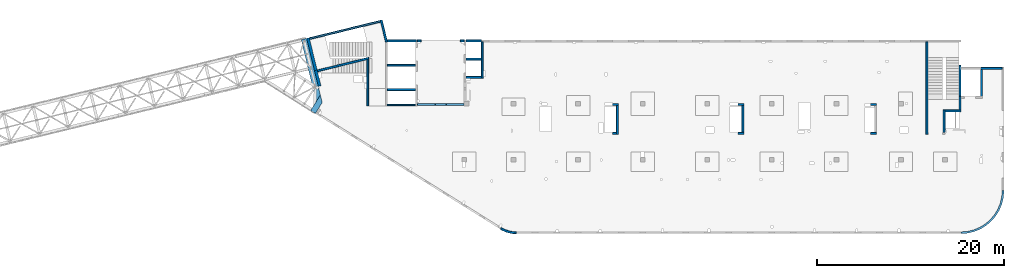
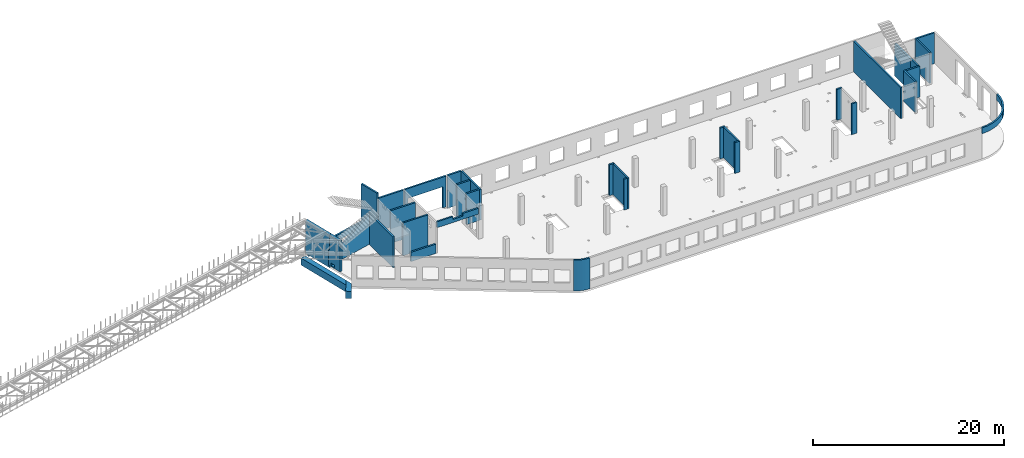
# One storey, part 15 of 66: 35 walls, 3 openings.
"""IFC4 building model written with IfcOpenShell, lengths in millimetres."""

from ifc_helpers import new_model, entity, si_unit, converted_unit, derived_unit, direction, frame, origin, place, context, subcontext, project, spatial, indexed_curve, outline, extrude, polygons, material, type_object, element, save


model = new_model("IFC4")

# Units and contexts
model_context = context("Model", 3, precision=0.01, world=origin(), true_north=direction((6.12303176911189e-17, 1.0)))
plan_context = context("Plan", 3, precision=0.01, world=origin(), true_north=direction((6.12303176911189e-17, 1.0)))
body_context = subcontext(model_context, "Body", "Model", "MODEL_VIEW")
ifc_project = project(units=[si_unit("LENGTHUNIT", "METRE", prefix="MILLI"), si_unit("AREAUNIT", "SQUARE_METRE"), si_unit("VOLUMEUNIT", "CUBIC_METRE"), converted_unit("PLANEANGLEUNIT", "DEGREE", entity("IfcRatioMeasure", 0.0174532925199433), si_unit("PLANEANGLEUNIT", "RADIAN"), dimensions=[0, 0, 0, 0, 0, 0, 0]), si_unit("MASSUNIT", "GRAM", prefix="KILO"), derived_unit("MASSDENSITYUNIT", [(si_unit("MASSUNIT", "GRAM", prefix="KILO"), 1), (si_unit("LENGTHUNIT", "METRE"), -3)]), derived_unit("MOMENTOFINERTIAUNIT", [(si_unit("LENGTHUNIT", "METRE"), 4)]), si_unit("TIMEUNIT", "SECOND"), si_unit("FREQUENCYUNIT", "HERTZ"), si_unit("THERMODYNAMICTEMPERATUREUNIT", "DEGREE_CELSIUS"), derived_unit("THERMALTRANSMITTANCEUNIT", [(si_unit("MASSUNIT", "GRAM", prefix="KILO"), 1), (si_unit("THERMODYNAMICTEMPERATUREUNIT", "KELVIN"), -1), (si_unit("TIMEUNIT", "SECOND"), -3)]), derived_unit("VOLUMETRICFLOWRATEUNIT", [(si_unit("LENGTHUNIT", "METRE"), 3), (si_unit("TIMEUNIT", "SECOND"), -1)]), derived_unit("MASSFLOWRATEUNIT", [(si_unit("MASSUNIT", "GRAM", prefix="KILO"), 1), (si_unit("TIMEUNIT", "SECOND"), -1)]), derived_unit("ROTATIONALFREQUENCYUNIT", [(si_unit("TIMEUNIT", "SECOND"), -1)]), si_unit("ELECTRICCURRENTUNIT", "AMPERE"), si_unit("ELECTRICVOLTAGEUNIT", "VOLT"), si_unit("POWERUNIT", "WATT"), si_unit("FORCEUNIT", "NEWTON", prefix="KILO"), si_unit("ILLUMINANCEUNIT", "LUX"), si_unit("LUMINOUSFLUXUNIT", "LUMEN"), si_unit("LUMINOUSINTENSITYUNIT", "CANDELA"), derived_unit("USERDEFINED", [(si_unit("MASSUNIT", "GRAM", prefix="KILO"), -1), (si_unit("LENGTHUNIT", "METRE"), -2), (si_unit("TIMEUNIT", "SECOND"), 3), (si_unit("LUMINOUSFLUXUNIT", "LUMEN"), 1)]), derived_unit("LINEARVELOCITYUNIT", [(si_unit("LENGTHUNIT", "METRE"), 1), (si_unit("TIMEUNIT", "SECOND"), -1)]), si_unit("PRESSUREUNIT", "PASCAL"), derived_unit("USERDEFINED", [(si_unit("LENGTHUNIT", "METRE"), -2), (si_unit("MASSUNIT", "GRAM", prefix="KILO"), 1), (si_unit("TIMEUNIT", "SECOND"), -2)]), derived_unit("LINEARFORCEUNIT", [(si_unit("MASSUNIT", "GRAM", prefix="KILO"), 1), (si_unit("LENGTHUNIT", "METRE"), 1), (si_unit("TIMEUNIT", "SECOND"), -2), (si_unit("LENGTHUNIT", "METRE"), -1)]), derived_unit("PLANARFORCEUNIT", [(si_unit("MASSUNIT", "GRAM", prefix="KILO"), 1), (si_unit("LENGTHUNIT", "METRE"), 1), (si_unit("TIMEUNIT", "SECOND"), -2), (si_unit("LENGTHUNIT", "METRE"), -2)])], contexts=[model_context, plan_context])

# Site, building, storey
site_placement = place(None, origin())
site = spatial("IfcSite", under=ifc_project, at=site_placement, CompositionType="ELEMENT")
building_placement = place(site_placement, origin())
building = spatial("IfcBuilding", under=site, at=building_placement, CompositionType="ELEMENT")
storey_placement = place(building_placement, frame((0.0, 0.0, 19800.0)))
storey = spatial("IfcBuildingStorey", under=building, at=storey_placement, Name="06", CompositionType="ELEMENT", Elevation=19800.0)

# Walls
ifc_material = material()
wall_type_1 = type_object("IfcWallType", Name=":ADSK_ 25_200", PredefinedType="STANDARD")
wall_1_placement = place(storey_placement, frame((45670.0, 13500.0, -150.0), z_axis=(0.0, 0.0, 1.0), x_axis=(0.0, -1.0, 0.0)))
element("IfcWall", 1, at=wall_1_placement, inside=storey, type_object=wall_type_1, material=ifc_material, Name=":ADSK_ 25_200", ObjectType=":ADSK_ 25_200", PredefinedType="NOTDEFINED", context=body_context, shape_type="SweptSolid", body=[
    extrude(outline(indexed_curve([(2874.99985044015, 100.000000000003), (0.0, 100.000000000003), (0.0, -100.000000000003), (2874.99985044015, -100.000000000003), (2874.99985044015, 100.000000000003)], self_intersect=False)), origin(), (0.0, 0.0, 1.0), 3950.0),
])
wall_2_placement = place(storey_placement, frame((32270.0, 13500.0, -150.0), z_axis=(0.0, 0.0, 1.0), x_axis=(0.0, -1.0, 0.0)))
element("IfcWall", 2, at=wall_2_placement, inside=storey, type_object=wall_type_1, material=ifc_material, Name=":ADSK_ 25_200", ObjectType=":ADSK_ 25_200", PredefinedType="NOTDEFINED", context=body_context, shape_type="SweptSolid", body=[
    extrude(outline(indexed_curve([(3074.99985044025, 99.9999999999989), (0.0, 99.9999999999989), (0.0, -99.9999999999989), (3074.99985044025, -99.9999999999989), (3074.99985044025, 99.9999999999989)], self_intersect=False)), origin(), (0.0, 0.0, 1.0), 3950.0),
])
wall_3_placement = place(storey_placement, frame((65330.0, 20300.0, -150.0), z_axis=(0.0, 0.0, 1.0), x_axis=(0.0, -1.0, 0.0)))
element("IfcWall", 3, at=wall_3_placement, inside=storey, type_object=wall_type_1, material=ifc_material, Name=":ADSK_ 25_200", ObjectType=":ADSK_ 25_200", PredefinedType="NOTDEFINED", context=body_context, shape_type="SweptSolid", body=[
    extrude(outline(indexed_curve([(9875.00063936714, 100.000000000003), (0.0, 100.000000000003), (0.0, -100.000000000003), (9875.00063936714, -100.000000000003), (9875.00063936714, 100.000000000003)], self_intersect=False)), origin(), (0.0, 0.0, 1.0), 3950.0),
])
wall_4_placement = place(storey_placement, frame((67180.0, 10625.0, -150.0), z_axis=(0.0, 0.0, 1.0), x_axis=(0.0, 1.0, 0.0)))
element("IfcWall", 4, at=wall_4_placement, inside=storey, type_object=wall_type_1, material=ifc_material, Name=":ADSK_ 25_200", ObjectType=":ADSK_ 25_200", PredefinedType="NOTDEFINED", context=body_context, shape_type="SweptSolid", body=[
    extrude(outline(indexed_curve([(2404.99999999995, 100.000000000003), (0.0, 100.000000000003), (0.0, -100.000000000003), (2404.99999999995, -100.000000000003), (2404.99999999995, 100.000000000003)], self_intersect=False)), origin(), (0.0, 0.0, 1.0), 3950.0),
])
wall_5_placement = place(storey_placement, frame((68870.0, 13030.0, -150.0), z_axis=(0.0, 0.0, 1.0), x_axis=(0.0, 1.0, 0.0)))
element("IfcWall", 5, at=wall_5_placement, inside=storey, type_object=wall_type_1, material=ifc_material, Name=":ADSK_ 25_200", ObjectType=":ADSK_ 25_200", PredefinedType="NOTDEFINED", context=body_context, shape_type="SweptSolid", body=[
    extrude(outline(indexed_curve([(1439.99999999999, 100.000000000003), (0.0, 100.000000000003), (0.0, -100.000000000003), (1439.99999999999, -100.000000000003), (1439.99999999999, 100.000000000003)], self_intersect=False)), origin(), (0.0, 0.0, 1.0), 3950.0),
])
wall_6_placement = place(storey_placement, frame((68970.0, 12930.0, -150.0), z_axis=(0.0, 0.0, 1.0), x_axis=(-1.0, 0.0, 0.0)))
element("IfcWall", 6, at=wall_6_placement, inside=storey, type_object=wall_type_1, material=ifc_material, Name=":ADSK_ 25_200", ObjectType=":ADSK_ 25_200", PredefinedType="NOTDEFINED", context=body_context, shape_type="SweptSolid", body=[
    extrude(outline(indexed_curve([(1689.99999999997, 100.000000000001), (-3.62972222111202e-13, 100.000000000001), (3.62972222111202e-13, -100.000000000001), (1689.99999999997, -100.000000000001), (1689.99999999997, 100.000000000001)], self_intersect=False)), origin(), (0.0, 0.0, 1.0), 3950.0),
])
wall_7_placement = place(storey_placement, frame((73370.0, 17470.0, -150.0), z_axis=(0.0, 0.0, 1.0), x_axis=(-1.0, 0.0, 0.0)))
element("IfcWall", 7, at=wall_7_placement, inside=storey, type_object=wall_type_1, material=ifc_material, Name=":ADSK_ 25_200", ObjectType=":ADSK_ 25_200", PredefinedType="NOTDEFINED", context=body_context, shape_type="SweptSolid", body=[
    extrude(outline(indexed_curve([(2300.00000000001, 99.9999999999992), (-2.9506601880044e-13, 99.9999999999989), (2.9506601880044e-13, -99.9999999999989), (2300.00000000001, -99.9999999999986), (2300.00000000001, 99.9999999999992)], self_intersect=False)), origin(), (0.0, 0.0, 1.0), 3950.0),
])
wall_8_placement = place(storey_placement, frame((71170.0, 14470.0, -150.0), z_axis=(0.0, 0.0, 1.0), x_axis=(0.0, 1.0, 0.0)))
element("IfcWall", 8, at=wall_8_placement, inside=storey, type_object=wall_type_1, material=ifc_material, Name=":ADSK_ 25_200", ObjectType=":ADSK_ 25_200", PredefinedType="NOTDEFINED", context=body_context, shape_type="SweptSolid", body=[
    extrude(outline(indexed_curve([(2900.0, 100.000000000003), (0.0, 100.000000000003), (0.0, -100.000000000003), (2900.0, -100.000000000003), (2900.0, 100.000000000003)], self_intersect=False)), origin(), (0.0, 0.0, 1.0), 3950.0),
])
wall_9_placement = place(storey_placement, frame((5723.68, 18543.92, -150.0), z_axis=(0.0, 0.0, 1.0), x_axis=(-0.971552058141474, -0.236826092990332, 0.0)))
element("IfcWall", 9, at=wall_9_placement, inside=storey, type_object=wall_type_1, material=ifc_material, Name=":ADSK_ 25_200", ObjectType=":ADSK_ 25_200", PredefinedType="NOTDEFINED", context=body_context, shape_type="Tessellation", body=[
    polygons([(0.0, -100.000000000001, 0.0), (5664.5968788743, -99.9999999999946, 0.0), (5664.5968788743, -99.9999999999946, 2020.0), (3907.95430516149, -99.9999999999989, 2020.0), (0.0, -100.000000000001, 3921.35271860844), (48.7521159583292, 100.000000000001, 0.0), (48.7521159583292, 100.000000000001, 3897.63315564096), (3907.95430516149, 100.000000000001, 2020.0), (5664.5968788743, 99.9999999999989, 2020.0), (5664.5968788743, 99.9999999999989, 0.0), (254.608300734047, 100.000000000003, 0.0), (5664.5968788743, 0.0, 2020.0)], [[[1, 2, 3, 4, 5]], [[6, 7, 8, 9, 10, 11]], [[1, 5, 7, 6]], [[3, 2, 10, 9, 12]], [[2, 1, 6, 11, 10]], [[4, 3, 12, 9, 8]], [[5, 4, 8, 7]]], closed=True),
])
wall_10_placement = place(storey_placement, frame((5600.0, 18435.22, -150.0), z_axis=(0.0, 0.0, 1.0), x_axis=(0.0, -1.0, 0.0)))
element("IfcWall", 10, at=wall_10_placement, inside=storey, type_object=wall_type_1, material=ifc_material, Name=":ADSK_ 25_200", ObjectType=":ADSK_ 25_200", PredefinedType="NOTDEFINED", context=body_context, shape_type="SweptSolid", body=[
    extrude(outline(indexed_curve([(4985.21659871757, -100.0), (4985.21659871757, 99.9999999999999), (2.01604199470658e-12, 100.0), (48.7521159583304, -99.9999999999999), (4985.21659871757, -100.0)], self_intersect=False)), origin(), (0.0, 0.0, 1.0), 3950.0),
])
wall_11_placement = place(storey_placement, frame((7033.44, 22609.75, -150.0), z_axis=(0.0, 0.0, 1.0), x_axis=(0.236826092990328, -0.971552058141475, 0.0)))
element("IfcWall", 11, at=wall_11_placement, inside=storey, type_object=wall_type_1, material=ifc_material, Name=":ADSK_ 25_200", ObjectType=":ADSK_ 25_200", PredefinedType="NOTDEFINED", context=body_context, shape_type="SweptSolid", body=[
    extrude(outline(indexed_curve([(2380.28371765147, -99.9999999999991), (2404.30804833169, 99.9999999999997), (2195.90383852408, 99.9999999999997), (1.1420864254319e-13, 99.9999999999997), (-1.1420864254319e-13, -99.9999999999997), (200.000000000008, -99.9999999999999), (2380.28371765147, -99.9999999999991)], self_intersect=False)), origin(), (0.0, 0.0, 1.0), 4700.0),
])
wall_12_placement = place(storey_placement, frame((7700.0, 15200.0, -400.0)))
element("IfcWall", 12, at=wall_12_placement, inside=storey, type_object=wall_type_1, material=ifc_material, Name=":ADSK_ 25_200", ObjectType=":ADSK_ 25_200", PredefinedType="NOTDEFINED", context=body_context, shape_type="SweptSolid", body=[
    extrude(outline(indexed_curve([(3000.0, 100.000000000001), (-2.88764567812907e-13, 100.000000000001), (2.88764567812907e-13, -100.000000000001), (3000.0, -100.000000000001), (3000.0, 100.000000000001)], self_intersect=False)), origin(), (0.0, 0.0, 1.0), 4200.0),
])
wall_13_placement = place(storey_placement, frame((7700.0, 17800.0, -400.0)))
element("IfcWall", 13, at=wall_13_placement, inside=storey, type_object=wall_type_1, material=ifc_material, Name=":ADSK_ 25_200", ObjectType=":ADSK_ 25_200", PredefinedType="NOTDEFINED", context=body_context, shape_type="SweptSolid", body=[
    extrude(outline(indexed_curve([(3000.0, 99.9999999999989), (-2.88764567812902e-13, 99.9999999999989), (2.88764567812902e-13, -99.9999999999989), (3000.0, -99.9999999999989), (3000.0, 99.9999999999989)], self_intersect=False)), origin(), (0.0, 0.0, 1.0), 4200.0),
])
wall_14_placement = place(storey_placement, frame((17825.0, 20300.0, -150.0), z_axis=(0.0, 0.0, 1.0), x_axis=(0.0, -1.0, 0.0)))
element("IfcWall", 14, at=wall_14_placement, inside=storey, type_object=wall_type_1, material=ifc_material, Name=":ADSK_ 25_200", ObjectType=":ADSK_ 25_200", PredefinedType="NOTDEFINED", context=body_context, shape_type="SweptSolid", body=[
    extrude(outline(indexed_curve([(3900.00063936684, 99.9999999999987), (6.05595613557109e-14, 99.9999999999989), (-6.05595613557109e-14, -99.9999999999989), (3900.00063936684, -99.9999999999991), (3900.00063936684, 99.9999999999987)], self_intersect=False)), origin(), (0.0, 0.0, 1.0), 3950.0),
])
wall_15_placement = place(storey_placement, frame((17725.0, 18450.0, -400.0), z_axis=(0.0, 0.0, 1.0), x_axis=(-1.0, 0.0, 0.0)))
element("IfcWall", 15, at=wall_15_placement, inside=storey, type_object=wall_type_1, material=ifc_material, Name=":ADSK_ 25_200", ObjectType=":ADSK_ 25_200", PredefinedType="NOTDEFINED", context=body_context, shape_type="SweptSolid", body=[
    extrude(outline(indexed_curve([(1625.0, 99.9999999999989), (-2.66551908750371e-13, 99.9999999999989), (2.66551908750371e-13, -99.9999999999989), (1625.0, -99.9999999999989), (1625.0, 99.9999999999989)], self_intersect=False)), origin(), (0.0, 0.0, 1.0), 4200.0),
])
wall_16_placement = place(storey_placement, frame((16100.0, 16500.0, -150.0)))
element("IfcWall", 16, at=wall_16_placement, inside=storey, type_object=wall_type_1, material=ifc_material, Name=":ADSK_ 25_200", ObjectType=":ADSK_ 25_200", PredefinedType="NOTDEFINED", context=body_context, shape_type="SweptSolid", body=[
    extrude(outline(indexed_curve([(1625.0, 99.9999999999989), (-2.66551908750371e-13, 99.9999999999989), (2.66551908750371e-13, -99.9999999999989), (1625.0, -99.9999999999989), (1625.0, 99.9999999999989)], self_intersect=False)), origin(), (0.0, 0.0, 1.0), 3950.0),
])
wall_17_placement = place(storey_placement, frame((19822.27, 371.04, -150.0)))
element("IfcWall", 17, at=wall_17_placement, inside=storey, type_object=wall_type_1, material=ifc_material, Name=":ADSK_ 25_200", ObjectType=":ADSK_ 25_200", PredefinedType="NOTDEFINED", context=body_context, shape_type="SweptSolid", body=[
    extrude(outline(indexed_curve([(1642.72666187733, -371.036494289582), (1475.26477394354, -366.358933709024), (1308.32509476025, -352.340838349344), (1142.4282046359, -329.025921870721), (978.091432072955, -296.486888895996), (815.827240544267, -254.825208290483), (656.141630440456, -204.170796744129), (499.532561171588, -144.68161364272), (346.48839834364, -76.5431684914861), (197.486390852038, 0.0320575728661979), (52.9911826412237, 84.8052743777455), (-52.9911826412064, -84.8052743777552), (101.137039450331, -175.230038969628), (260.072514108048, -256.91028010494), (423.319621124515, -329.591288266255), (590.36929501131, -393.046416907758), (760.700612455376, -447.077789223871), (933.78241675264, -491.516915203086), (1109.07497415312, -526.225217042794), (1286.03165695242, -551.094461286659), (1464.10064808126, -566.047096336985), (1642.72666187731, -571.036494289582), (1642.72666187733, -371.036494289582)], self_intersect=False)), origin(), (0.0, 0.0, 1.0), 3950.0),
])
wall_18_placement = place(storey_placement, frame((73470.0, 4400.0, 3050.0)))
element("IfcWall", 18, at=wall_18_placement, inside=storey, type_object=wall_type_1, material=ifc_material, Name=":ADSK_ 25_200", ObjectType=":ADSK_ 25_200", PredefinedType="NOTDEFINED", context=body_context, shape_type="SweptSolid", body=[
    extrude(outline(indexed_curve([(-4499.99918212898, -4599.99918212887), (-3780.40077088714, -4543.36555893587), (-3078.52126074028, -4374.85919711607), (-2411.64325463275, -4098.62928253802), (-1796.18750231614, -3721.47751245316), (-1247.30856699303, -3252.69061513595), (-778.521669675789, -2703.81167981284), (-401.369899590915, -2088.35592749624), (-125.139985012846, -1421.47792138872), (43.366376806984, -719.59841124187), (100.000000000003, -3.19445803143026e-11), (-99.9999999999946, 0.0), (-154.171291312042, -688.311518233791), (-315.351288271866, -1359.67452251371), (-579.571204428578, -1997.5578275483), (-940.325068550761, -2586.25462935432), (-1388.72992323031, -3111.26925889861), (-1913.74455277461, -3559.67411357815), (-2502.44135458064, -3920.42797770033), (-3140.32465961524, -4184.64789385703), (-3811.68766389516, -4345.82789081684), (-4499.99918212895, -4399.99918212887), (-4499.99918212898, -4599.99918212887)], self_intersect=False)), origin(), (0.0, 0.0, 1.0), 750.000000000003),
])
wall_19_placement = place(storey_placement, frame((32170.0, 10525.0, -150.0), z_axis=(0.0, 0.0, 1.0), x_axis=(-1.0, 0.0, 0.0)))
element("IfcWall", 19, at=wall_19_placement, inside=storey, type_object=wall_type_1, material=ifc_material, Name=":ADSK_ 25_200", ObjectType=":ADSK_ 25_200", PredefinedType="NOTDEFINED", context=body_context, shape_type="SweptSolid", body=[
    extrude(outline(indexed_curve([(400.0, 99.9999999999981), (-3.43767342634407e-13, 99.9999999999989), (3.43767342634407e-13, -99.9999999999989), (400.0, -99.9999999999997), (400.0, 99.9999999999981)], self_intersect=False)), origin(), (0.0, 0.0, 1.0), 3950.0),
])
wall_20_placement = place(storey_placement, frame((32370.0, 13600.0, -150.0), z_axis=(0.0, 0.0, 1.0), x_axis=(-1.0, 0.0, 0.0)))
element("IfcWall", 20, at=wall_20_placement, inside=storey, type_object=wall_type_1, material=ifc_material, Name=":ADSK_ 25_200", ObjectType=":ADSK_ 25_200", PredefinedType="NOTDEFINED", context=body_context, shape_type="SweptSolid", body=[
    extrude(outline(indexed_curve([(600.000000000002, 99.9999999999979), (-5.58957591434401e-13, 99.9999999999989), (5.58957591434401e-13, -99.9999999999989), (600.000000000003, -99.9999999999999), (600.000000000002, 99.9999999999979)], self_intersect=False)), origin(), (0.0, 0.0, 1.0), 3950.0),
])
wall_21_placement = place(storey_placement, frame((45770.0, 13600.0, -150.0), z_axis=(0.0, 0.0, 1.0), x_axis=(-1.0, 0.0, 0.0)))
element("IfcWall", 21, at=wall_21_placement, inside=storey, type_object=wall_type_1, material=ifc_material, Name=":ADSK_ 25_200", ObjectType=":ADSK_ 25_200", PredefinedType="NOTDEFINED", context=body_context, shape_type="SweptSolid", body=[
    extrude(outline(indexed_curve([(599.999999999993, 99.9999999999978), (-5.41433564649196e-13, 99.9999999999989), (5.41433564649196e-13, -99.9999999999989), (599.999999999994, -100.0), (599.999999999993, 99.9999999999978)], self_intersect=False)), origin(), (0.0, 0.0, 1.0), 3950.0),
])
wall_22_placement = place(storey_placement, frame((45770.0, 10525.0, -150.0), z_axis=(0.0, 0.0, 1.0), x_axis=(-1.0, 0.0, 0.0)))
element("IfcWall", 22, at=wall_22_placement, inside=storey, type_object=wall_type_1, material=ifc_material, Name=":ADSK_ 25_200", ObjectType=":ADSK_ 25_200", PredefinedType="NOTDEFINED", context=body_context, shape_type="SweptSolid", body=[
    extrude(outline(indexed_curve([(600.000000000002, 99.9999999999978), (-5.39089922916519e-13, 99.9999999999989), (5.39089922916519e-13, -99.9999999999989), (600.000000000003, -100.0), (600.000000000002, 99.9999999999978)], self_intersect=False)), origin(), (0.0, 0.0, 1.0), 3950.0),
])
wall_23_placement = place(storey_placement, frame((59930.0, 13600.0, -150.0), z_axis=(0.0, 0.0, 1.0), x_axis=(-1.0, 0.0, 0.0)))
element("IfcWall", 23, at=wall_23_placement, inside=storey, type_object=wall_type_1, material=ifc_material, Name=":ADSK_ 25_200", ObjectType=":ADSK_ 25_200", PredefinedType="NOTDEFINED", context=body_context, shape_type="SweptSolid", body=[
    extrude(outline(indexed_curve([(600.00000000001, 99.9999999999978), (-5.41433564649173e-13, 99.9999999999989), (5.41433564649173e-13, -99.9999999999989), (600.000000000011, -100.0), (600.00000000001, 99.9999999999978)], self_intersect=False)), origin(), (0.0, 0.0, 1.0), 3950.0),
])
wall_24_placement = place(storey_placement, frame((59930.0, 10525.0, -150.0), z_axis=(0.0, 0.0, 1.0), x_axis=(-1.0, 0.0, 0.0)))
element("IfcWall", 24, at=wall_24_placement, inside=storey, type_object=wall_type_1, material=ifc_material, Name=":ADSK_ 25_200", ObjectType=":ADSK_ 25_200", PredefinedType="NOTDEFINED", context=body_context, shape_type="SweptSolid", body=[
    extrude(outline(indexed_curve([(599.999999999994, 99.9999999999989), (0.0, 99.9999999999989), (0.0, -99.9999999999989), (599.999999999994, -99.9999999999989), (599.999999999994, 99.9999999999989)], self_intersect=False)), origin(), (0.0, 0.0, 1.0), 3950.0),
])

# Wall, opening
wall_25_placement = place(storey_placement, frame((10900.0, 13600.0, 3050.0)))
wall_25 = element("IfcWall", 25, at=wall_25_placement, inside=storey, type_object=wall_type_1, material=ifc_material, Name=":ADSK_ 25_200", ObjectType=":ADSK_ 25_200", PredefinedType="NOTDEFINED", context=body_context, shape_type="Tessellation", body=[
    polygons([(2.16569675683432e-13, -100.000000000001, 0.0), (4999.99925537109, -100.000000000001, 0.0), (4999.99925537109, -100.000000000001, 749.999999999998), (3100.0, -99.9999999999989, 749.999999999998), (3100.0, -99.9999999999989, 400.0), (1900.0, -100.000000000001, 400.0), (1900.0, -100.000000000001, 749.999999999998), (2.16569675683432e-13, -100.000000000001, 749.999999999998), (1.77589825156368e-12, 99.9999999999989, 0.0), (-3.89836007033108e-13, 99.9999999999989, 749.999999999998), (1900.0, 99.9999999999989, 749.999999999998), (1900.0, 99.9999999999989, 400.0), (3100.0, 100.000000000001, 400.0), (3100.0, 100.000000000001, 749.999999999998), (4999.99925537109, 99.9999999999989, 749.999999999998), (4999.99925537109, 99.9999999999989, 0.0)], [[[1, 2, 3, 4, 5, 6, 7, 8]], [[9, 10, 11, 12, 13, 14, 15, 16]], [[1, 8, 10, 9]], [[2, 1, 9, 16]], [[3, 2, 16, 15]], [[4, 3, 15, 14]], [[5, 4, 14, 13]], [[6, 5, 13, 12]], [[7, 6, 12, 11]], [[8, 7, 11, 10]]], closed=True),
])
opening_1_placement = place(wall_25_placement, origin())
element("IfcOpeningElement", 26, at=opening_1_placement, cuts=wall_25, Name=":ADSK_ 25_200", PredefinedType="OPENING", context=body_context, shape_type="SweptSolid", body=[
    extrude(outline(indexed_curve([(-599.999999999998, -174.999999999999), (600.000000000002, -174.999999999999), (600.000000000002, 174.999999999999), (-599.999999999998, 174.999999999999), (-599.999999999998, -174.999999999999)], self_intersect=False)), frame((2500.0, 100.0, 575.0), z_axis=(0.0, -1.0, 0.0), x_axis=(-1.0, 0.0, 0.0)), (0.0, 0.0, 1.0), 200.0),
])

# Walls
wall_26_placement = place(storey_placement, frame((-618.13, 20641.67, -900.0), z_axis=(0.0, 0.0, 1.0), x_axis=(0.971552058141473, 0.236826092990338, 0.0)))
element("IfcWall", 27, at=wall_26_placement, inside=storey, type_object=wall_type_1, material=ifc_material, Name=":ADSK_ 25_200", ObjectType=":ADSK_ 25_200", PredefinedType="NOTDEFINED", context=body_context, shape_type="SweptSolid", body=[
    extrude(outline(indexed_curve([(7799.9920696628, 100.0), (-5.4989346409684e-14, 100.0), (5.4989346409684e-14, -100.0), (7799.9920696628, -100.0), (7799.9920696628, 100.0)], self_intersect=False)), origin(), (0.0, 0.0, 1.0), 750.000000000003),
])
wall_27_placement = place(storey_placement, frame((68870.0, 14270.0, -400.0), z_axis=(0.0, 0.0, 1.0), x_axis=(0.0, 1.0, 0.0)))
element("IfcWall", 28, at=wall_27_placement, inside=storey, type_object=wall_type_1, material=ifc_material, Name=":ADSK_ 25_200", ObjectType=":ADSK_ 25_200", PredefinedType="NOTDEFINED", context=body_context, shape_type="SweptSolid", body=[
    extrude(outline(indexed_curve([(3510.0, -99.9999999999946), (3510.0, 100.000000000003), (200.0, 100.000000000003), (0.0, 100.000000000003), (0.0, -99.9999999999946), (200.0, -99.9999999999946), (3100.0, -99.9999999999946), (3300.0, -99.9999999999946), (3510.0, -99.9999999999946)], self_intersect=False)), origin(), (0.0, 0.0, 1.0), 4200.0),
])
wall_28_placement = place(storey_placement, frame((17725.0, 20400.0, -400.0), z_axis=(0.0, 0.0, 1.0), x_axis=(-1.0, 0.0, 0.0)))
element("IfcWall", 29, at=wall_28_placement, inside=storey, type_object=wall_type_1, material=ifc_material, Name=":ADSK_ 25_200", ObjectType=":ADSK_ 25_200", PredefinedType="NOTDEFINED", context=body_context, shape_type="SweptSolid", body=[
    extrude(outline(indexed_curve([(1624.99999999999, 99.9999999999988), (8.49307538770806e-15, 99.9999999999989), (-8.49307538770806e-15, -99.9999999999989), (1624.99999999999, -99.9999999999991), (1624.99999999999, 99.9999999999988)], self_intersect=False)), origin(), (0.0, 0.0, 1.0), 4200.0),
])

# Wall, opening
wall_29_placement = place(storey_placement, frame((15900.0, 20400.0, -150.0), z_axis=(0.0, 0.0, 1.0), x_axis=(-1.0, 0.0, 0.0)))
wall_29 = element("IfcWall", 30, at=wall_29_placement, inside=storey, type_object=wall_type_1, material=ifc_material, Name=":ADSK_ 25_200", ObjectType=":ADSK_ 25_200", PredefinedType="NOTDEFINED", context=body_context, shape_type="Tessellation", body=[
    polygons([(5000.00000000001, -99.9999999999989, 3950.0), (4.24653815520889e-13, -99.9999999999989, 3950.0), (4.24653815520889e-13, -99.9999999999989, 0.0), (400.000000000013, -99.9999999999989, 0.0), (400.000000000013, -99.9999999999989, 2699.99999999804), (4600.00000000001, -99.9999999999989, 2699.99999999804), (4600.00000000001, -99.9999999999989, 0.0), (5000.00000000001, -99.9999999999989, 0.0), (4.41639966296306e-13, 99.9999999999989, 3950.0), (5000.00000000001, 99.9999999999989, 3950.0), (5000.00000000001, 99.9999999999989, 0.0), (4600.00000000001, 99.9999999999989, 0.0), (4600.00000000001, 99.9999999999989, 2699.99999999804), (400.000000000013, 99.9999999999989, 2699.99999999804), (400.000000000013, 99.9999999999989, 0.0), (4.41639966296306e-13, 99.9999999999989, 0.0)], [[[1, 2, 3, 4, 5, 6, 7, 8]], [[9, 10, 11, 12, 13, 14, 15, 16]], [[3, 16, 15, 4]], [[2, 1, 10, 9]], [[13, 6, 5, 14]], [[14, 5, 4, 15]], [[6, 13, 12, 7]], [[3, 2, 9, 16]], [[8, 11, 10, 1]], [[11, 8, 7, 12]]], closed=True),
])
opening_2_placement = place(wall_29_placement, frame((15900.0, 20400.0, 150.0), z_axis=(0.0, 0.0, 1.0), x_axis=(-1.0, 0.0, 0.0)))
element("IfcOpeningElement", 31, at=opening_2_placement, cuts=wall_29, Name=":ADSK_ 25_200", PredefinedType="OPENING", context=body_context, shape_type="SweptSolid", body=[
    extrude(outline(indexed_curve([(-1349.99999999902, -2100.0), (1349.99999999902, -2100.0), (1349.99999999902, 2100.0), (-1349.99999999902, 2100.0), (-1349.99999999902, -2100.0)], self_intersect=False)), frame((13400.0, 20600.0, 1200.0), z_axis=(0.0, -1.0, 0.0), x_axis=(0.0, 0.0, -1.0)), (0.0, 0.0, 1.0), 400.000000001945),
])

# Walls
wall_30_placement = place(storey_placement, frame((10800.0, 20400.0, -400.0), z_axis=(0.0, 0.0, 1.0), x_axis=(-1.0, 0.0, 0.0)))
element("IfcWall", 32, at=wall_30_placement, inside=storey, type_object=wall_type_1, material=ifc_material, Name=":ADSK_ 25_200", ObjectType=":ADSK_ 25_200", PredefinedType="NOTDEFINED", context=body_context, shape_type="SweptSolid", body=[
    extrude(outline(indexed_curve([(3149.35561234222, -99.9999999999992), (3100.6034963839, 99.9999999999987), (8.49307538770806e-15, 99.9999999999989), (-8.49307538770806e-15, -99.9999999999989), (99.9999999999946, -99.9999999999989), (3149.35561234222, -99.9999999999992)], self_intersect=False)), origin(), (0.0, 0.0, 1.0), 4200.0),
])
wall_31_placement = place(storey_placement, frame((7700.0, 13550.0, -150.0)))
element("IfcWall", 33, at=wall_31_placement, inside=storey, type_object=wall_type_1, material=ifc_material, Name=":ADSK_ 25_200", ObjectType=":ADSK_ 25_200", PredefinedType="NOTDEFINED", context=body_context, shape_type="SweptSolid", body=[
    extrude(outline(indexed_curve([(3000.0, 99.9999999999989), (-2.88764567812901e-13, 99.9999999999989), (2.88764567812901e-13, -99.9999999999989), (3000.0, -99.9999999999989), (3000.0, 99.9999999999989)], self_intersect=False)), origin(), (0.0, 0.0, 1.0), 1200.0),
])

# Wall, opening
wall_type_2 = type_object("IfcWallType", Name=":ADSK_ 25_300", PredefinedType="STANDARD")
wall_32_placement = place(storey_placement, frame((462.89, 15573.53, -150.0), z_axis=(0.0, 0.0, 1.0), x_axis=(-0.236826092990339, 0.971552058141473, 0.0)))
wall_32 = element("IfcWall", 34, at=wall_32_placement, inside=storey, type_object=wall_type_2, material=ifc_material, Name=":ADSK_ 25_300", ObjectType=":ADSK_ 25_300", PredefinedType="NOTDEFINED", context=body_context, shape_type="Tessellation", body=[
    polygons([(0.0, -150.0, 0.0), (1539.99447706125, -150.0, 0.0), (1739.99447706125, -149.999999999999, 0.0), (1739.99447706125, -150.0, 49.9999999999973), (1739.99447706125, -149.999999999999, 2020.0), (1639.99447706125, -150.0, 2020.0), (1639.99447706125, -150.0, 3950.0), (0.0, -150.0, 3950.0), (879.994477076674, -149.999999999999, 449.999999999997), (1379.99447707667, -150.0, 449.999999999997), (1379.99447707667, -150.0, 150.000000000009), (879.994477076674, -149.999999999999, 150.000000000009), (-2.16573425859679e-12, 150.000000000001, 0.0), (-2.16573425859679e-12, 150.000000000001, 3950.0), (1463.63192277804, 150.000000000001, 3950.0), (1639.99447706125, 150.000000000001, 3950.0), (1639.99447706125, 150.000000000001, 2020.0), (1739.99447706126, 150.000000000001, 2020.0), (1739.99447706126, 150.000000000001, 0.0), (1539.97976766027, 150.0, 0.0), (1379.99447707668, 150.000000000321, 449.999999999997), (879.994477076672, 150.000000000321, 449.999999999997), (879.994477076672, 150.000000000321, 150.000000000009), (1379.99447707668, 150.000000000321, 150.000000000009)], [[[1, 2, 3, 4, 5, 6, 7, 8], [9, 10, 11, 12]], [[13, 14, 15, 16, 17, 18, 19, 20], [21, 22, 23, 24]], [[3, 2, 1, 13, 20, 19]], [[8, 7, 16, 15, 14]], [[1, 8, 14, 13]], [[22, 21, 10, 9]], [[22, 9, 12, 23]], [[23, 12, 11, 24]], [[10, 21, 24, 11]], [[7, 6, 17, 16]], [[17, 6, 5, 18]], [[3, 19, 18, 5, 4]]], closed=True),
])
opening_3_placement = place(wall_32_placement, frame((-15020.87, 4137.94, 150.0), z_axis=(0.0, 0.0, 1.0), x_axis=(-0.236826092990339, -0.971552058141473, 0.0)))
element("IfcOpeningElement", 35, at=opening_3_placement, cuts=wall_32, Name=":ADSK_ 25_300", PredefinedType="OPENING", context=body_context, shape_type="SweptSolid", body=[
    extrude(outline(indexed_curve([(-149.999999999992, -250.0), (149.999999999992, -250.0), (149.999999999992, 250.0), (-149.999999999992, 250.0), (-149.999999999992, -250.0)], self_intersect=False)), frame((341.01, 16706.9, 150.0), z_axis=(-0.971552058141473, -0.236826092990339, 0.0), x_axis=(0.0, 0.0, -1.0)), (0.0, 0.0, 1.0), 300.000000000962),
])

# Walls
wall_33_placement = place(storey_placement, frame((98.19, 17069.7, -400.0), z_axis=(0.0, 0.0, 1.0), x_axis=(-0.236826092990339, 0.971552058141473, 0.0)))
element("IfcWall", 36, at=wall_33_placement, inside=storey, type_object=wall_type_2, material=ifc_material, Name=":ADSK_ 25_300", ObjectType=":ADSK_ 25_300", PredefinedType="NOTDEFINED", context=body_context, shape_type="SweptSolid", body=[
    extrude(outline(indexed_curve([(-1.69197988952874e-13, 150.0), (2.03037586743449e-13, -150.0), (3539.99999999998, -150.0), (3739.99999999999, -150.0), (3739.99999999999, 150.0), (-1.69197988952874e-13, 150.0)], self_intersect=False)), origin(), (0.0, 0.0, 1.0), 4200.0),
])
wall_type_3 = type_object("IfcWallType", Name=":ADSK_ 25_600", PredefinedType="STANDARD")
wall_34_placement = place(storey_placement, frame((-254.56, 12798.44, -1650.0), z_axis=(0.0, 0.0, 1.0), x_axis=(0.529911826412025, 0.848052743777574, 0.0)))
element("IfcWall", 37, at=wall_34_placement, inside=storey, type_object=wall_type_3, material=ifc_material, Name=":ADSK_ 25_600", ObjectType=":ADSK_ 25_600", PredefinedType="NOTDEFINED", context=body_context, shape_type="SweptSolid", body=[
    extrude(outline(indexed_curve([(1389.90316371841, -299.999999999999), (1975.44344544941, 300.0), (1137.07752204268, 300.0), (4.22994972382185e-13, 300.000000000001), (1.11670672708897e-12, -299.999999999999), (1389.90316371841, -299.999999999999)], self_intersect=False)), origin(), (0.0, 0.0, 1.0), 900.000000000003),
])
wall_35_placement = place(storey_placement, frame((385.04, 13992.76, -1650.0), z_axis=(0.0, 0.0, 1.0), x_axis=(-0.236826092990339, 0.971552058141473, 0.0)))
element("IfcWall", 38, at=wall_35_placement, inside=storey, type_object=wall_type_3, material=ifc_material, Name=":ADSK_ 25_600", ObjectType=":ADSK_ 25_600", PredefinedType="NOTDEFINED", context=body_context, shape_type="SweptSolid", body=[
    extrude(outline(indexed_curve([(6797.33784608927, -300.0), (6797.33784608927, 300.0), (-3.13016279562817e-13, 300.0), (585.540281731007, -300.0), (6797.33784608927, -300.0)], self_intersect=False)), origin(), (0.0, 0.0, 1.0), 900.000000000003),
])

save(model, "model.ifc")
